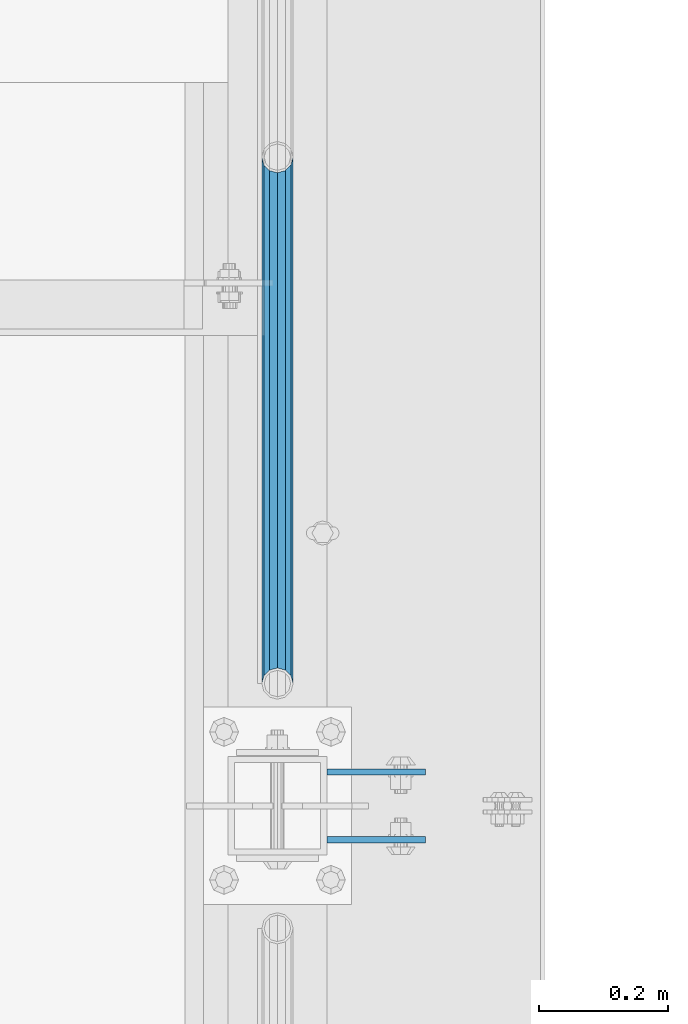
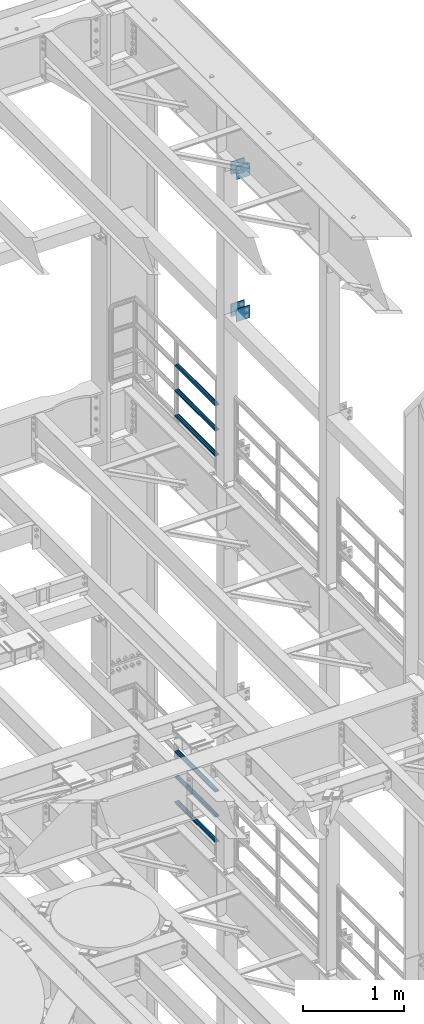
# One storey, part 1349 of 1876: 10 beams, 3 elements without a shape of their own.
"""IFC2X3 building model written with IfcOpenShell, lengths in millimetres."""

from ifc_helpers import new_model, si_unit, frame, origin_with_axes, place, context, subcontext, project, spatial, faceted_brep, material, type_object, element, aggregate, save


model = new_model("IFC2X3")

# Units and contexts
model_context = context("Model", 3, precision=1e-05, world=origin_with_axes())
body_context = subcontext(model_context, "Body", "Model", "MODEL_VIEW")
ifc_project = project(units=[si_unit("LENGTHUNIT", "METRE", prefix="MILLI"), si_unit("AREAUNIT", "SQUARE_METRE"), si_unit("VOLUMEUNIT", "CUBIC_METRE"), si_unit("MASSUNIT", "GRAM", prefix="KILO"), si_unit("TIMEUNIT", "SECOND"), si_unit("PLANEANGLEUNIT", "RADIAN"), si_unit("SOLIDANGLEUNIT", "STERADIAN"), si_unit("THERMODYNAMICTEMPERATUREUNIT", "DEGREE_CELSIUS"), si_unit("LUMINOUSINTENSITYUNIT", "LUMEN")], contexts=[model_context])

# Site, building, storey
site_placement = place(None, origin_with_axes())
site = spatial("IfcSite", under=ifc_project, at=site_placement, CompositionType="ELEMENT")
building_placement = place(site_placement, origin_with_axes())
building = spatial("IfcBuilding", under=site, at=building_placement, Name="Undefined", CompositionType="ELEMENT")
storey_placement = place(building_placement, origin_with_axes())
storey = spatial("IfcBuildingStorey", under=building, at=storey_placement, Name="Undefined", CompositionType="ELEMENT", Elevation=0.0)

# Assembly, beams
assembly_1_placement = place(storey_placement, origin_with_axes())
assembly_1 = element("IfcElementAssembly", 1, at=assembly_1_placement, inside=storey, Name="BEAM", AssemblyPlace="NOTDEFINED", PredefinedType="RIGID_FRAME")
ifc_material_1 = material(Name="STEEL/A36")
beam_type_1 = type_object("IfcBeamType", PredefinedType="NOTDEFINED")
beam_1_placement = place(assembly_1_placement, frame((7696.20000025489, 11736.3875, 21678.9), z_axis=(0.0, 0.0, -1.0), x_axis=(1.0, 0.0, 0.0)))
beam_1 = element("IfcBeam", 2, at=beam_1_placement, type_object=beam_type_1, material=ifc_material_1, Name="PLATE", context=body_context, shape_type="Brep", body=[
    faceted_brep([(0.0, 4.76249999999982, -76.1999999999998), (3.63797880709171e-12, 4.76249999999982, 76.1999969482422), (152.399993896484, 4.76250000000073, 76.1999969482422), (152.4, 4.76249999999982, -76.1999999999998), (3.63797880709171e-12, -4.76249999999982, 76.1999969482422), (152.399993896484, -4.76250000000073, 76.1999969482422), (0.0, -4.76249999999982, -76.1999999999998), (152.4, -4.76249999999982, -76.1999999999998)], [[[0, 1, 2, 3]], [[4, 5, 2, 1]], [[4, 6, 7, 5]], [[6, 0, 3, 7]], [[5, 7, 3, 2]], [[6, 4, 1, 0]]]),
])
beam_2_placement = place(assembly_1_placement, frame((7696.20000025489, 11631.6125, 21678.9), z_axis=(0.0, 0.0, -1.0), x_axis=(1.0, 0.0, 0.0)))
beam_2 = element("IfcBeam", 3, at=beam_2_placement, type_object=beam_type_1, material=ifc_material_1, Name="PLATE", context=body_context, shape_type="Brep", body=[
    faceted_brep([(0.0, 4.76249999999982, -76.1999999999998), (3.63797880709171e-12, 4.76249999999982, 76.1999969482422), (152.399993896484, 4.76250000000073, 76.1999969482422), (152.4, 4.76249999999982, -76.1999999999998), (3.63797880709171e-12, -4.76249999999982, 76.1999969482422), (152.399993896484, -4.76250000000073, 76.1999969482422), (0.0, -4.76249999999982, -76.1999999999998), (152.4, -4.76249999999982, -76.1999999999998)], [[[0, 1, 2, 3]], [[4, 5, 2, 1]], [[4, 6, 7, 5]], [[6, 0, 3, 7]], [[5, 7, 3, 2]], [[6, 4, 1, 0]]]),
])
beam_3_placement = place(assembly_1_placement, frame((7696.20000025489, 11736.3875, 19958.05), z_axis=(0.0, 0.0, -1.0), x_axis=(1.0, 0.0, 0.0)))
beam_3 = element("IfcBeam", 4, at=beam_3_placement, type_object=beam_type_1, material=ifc_material_1, Name="PLATE", context=body_context, shape_type="Brep", body=[
    faceted_brep([(0.0, 4.76249999999982, -76.1999999999998), (3.63797880709171e-12, 4.76249999999982, 76.1999969482422), (152.399993896484, 4.76250000000073, 76.1999969482422), (152.4, 4.76249999999982, -76.1999999999998), (3.63797880709171e-12, -4.76249999999982, 76.1999969482422), (152.399993896484, -4.76250000000073, 76.1999969482422), (0.0, -4.76249999999982, -76.1999999999998), (152.4, -4.76249999999982, -76.1999999999998)], [[[0, 1, 2, 3]], [[4, 5, 2, 1]], [[4, 6, 7, 5]], [[6, 0, 3, 7]], [[5, 7, 3, 2]], [[6, 4, 1, 0]]]),
])
beam_4_placement = place(assembly_1_placement, frame((7696.20000025489, 11631.6125, 19958.05), z_axis=(0.0, 0.0, -1.0), x_axis=(1.0, 0.0, 0.0)))
beam_4 = element("IfcBeam", 5, at=beam_4_placement, type_object=beam_type_1, material=ifc_material_1, Name="PLATE", context=body_context, shape_type="Brep", body=[
    faceted_brep([(0.0, 4.76249999999982, -76.1999999999998), (3.63797880709171e-12, 4.76249999999982, 76.1999969482422), (152.399993896484, 4.76250000000073, 76.1999969482422), (152.4, 4.76249999999982, -76.1999999999998), (3.63797880709171e-12, -4.76249999999982, 76.1999969482422), (152.399993896484, -4.76250000000073, 76.1999969482422), (0.0, -4.76249999999982, -76.1999999999998), (152.4, -4.76249999999982, -76.1999999999998)], [[[0, 1, 2, 3]], [[4, 5, 2, 1]], [[4, 6, 7, 5]], [[6, 0, 3, 7]], [[5, 7, 3, 2]], [[6, 4, 1, 0]]]),
])
aggregate(assembly_1, [beam_1, beam_2, beam_3, beam_4])

assembly_2_placement = place(storey_placement, origin_with_axes())
assembly_2 = element("IfcElementAssembly", 6, at=assembly_2_placement, inside=storey, Name="RAIL", AssemblyPlace="NOTDEFINED", PredefinedType="RIGID_FRAME")
ifc_material_2 = material()
beam_type_2 = type_object("IfcBeamType", Name="PIPE1-1/2SCH40", PredefinedType="NOTDEFINED")
beam_5_placement = place(assembly_2_placement, frame((7619.99999999997, 12686.3094, 18145.125), z_axis=(0.0, 0.0, 1.0), x_axis=(0.0, -1.0, 0.0)))
beam_5 = element("IfcBeam", 7, at=beam_5_placement, type_object=beam_type_2, material=ifc_material_2, Name="RAIL", ObjectType="PIPE1-1/2SCH40", context=body_context, shape_type="Brep", body=[
    faceted_brep([(792.499707006684, -12.0649999999996, 20.8971929933177), (792.499707006684, -12.0650000000314, 15.8661214311469), (792.006278568813, -10.2235000000001, 17.7076214311819), (789.266900000001, -9.09494701772928e-13, 20.4470000000001), (789.266900000001, -9.09494701772928e-13, 24.130000000001), (792.00627856883, 10.2235000000001, 17.7076214311819), (792.499707006684, 12.0649999999678, 15.8661214312124), (792.499707006684, 12.0649999999996, 20.8971929933177), (813.396900000002, 24.1300000000001, 0.0), (801.331900000001, 20.8971929933186, 12.0649999999987), (801.331900000001, 20.8971929933186, -12.0649999999987), (798.142328437896, 17.7076214311801, 10.2235000000001), (800.881707006714, 20.4470000000001, 0.0), (798.142328437896, 17.7076214311801, -10.2235000000001), (792.499707006684, 12.0649999999678, -15.8661214312124), (792.499707006684, 12.0649999999996, -20.8971929933177), (792.00627856883, 10.2235000000001, -17.7076214311819), (789.266900000001, 0.0, -20.4470000000001), (789.266900000001, 0.0, -24.130000000001), (792.499707006684, -12.0650000000314, -15.8661214311469), (792.499707006684, -12.0649999999996, -20.8971929933177), (792.006278568813, -10.2235000000001, -17.7076214311819), (813.396900000002, -24.1300000000319, 0.0), (801.331900000001, -20.8971929933186, -12.0649999999987), (801.331900000001, -20.8971929933186, 12.0649999999987), (798.142328437831, -17.7076214311801, -10.2235000000001), (800.881707006651, -20.4470000000001, 0.0), (798.142328437831, -17.7076214311801, 10.2235000000001), (12.0650000000064, -20.8971929933177, -12.0649999999987), (20.8971929933249, -12.0650000000005, -20.8971929933177), (0.0, 24.1299999999992, 0.0), (12.0650000000064, 20.8971929933177, -12.0649999999987), (12.0650000000064, 20.8971929933177, 12.0649999999987), (20.8971929933249, 12.0650000000005, 20.8971929933177), (24.1300000000064, 0.0, 24.130000000001), (20.8971929933249, 12.0650000000005, -20.8971929933177), (24.1300000000063, 0.0, -24.130000000001), (24.1300000000063, 0.0, -20.4470000000001), (20.8971929933249, -12.0650000000005, -15.8661214311796), (21.3906214311868, -10.2235000000001, -17.7076214311819), (21.3906214311868, 10.2235000000001, -17.7076214311819), (20.8971929933249, 12.0650000000005, -15.8661214311796), (15.2545715621445, 17.7076214311801, -10.2235000000001), (12.5151929933249, 20.4470000000001, 0.0), (15.2545715621445, 17.7076214311801, 10.2235000000001), (20.8971929933249, 12.0650000000005, 15.8661214311796), (21.3906214311868, 10.2235000000001, 17.7076214311819), (24.1300000000064, 0.0, 20.4470000000001), (21.3906214311868, -10.2235000000001, 17.7076214311819), (20.8971929933249, -12.0650000000005, 15.8661214311796), (20.8971929933249, -12.0650000000005, 20.8971929933177), (12.0650000000064, -20.8971929933177, 12.0649999999987), (0.0, -24.1299999999992, 0.0), (15.2545715621445, -17.7076214311801, 10.2235000000001), (12.5151929933249, -20.4470000000001, 0.0), (15.2545715621445, -17.7076214311801, -10.2235000000001)], [[[0, 1, 2, 3, 4]], [[4, 3, 5, 6, 7]], [[8, 9, 10]], [[7, 6, 11, 12, 13, 14, 15, 10, 9]], [[16, 17, 18, 15, 14]], [[19, 20, 18, 17, 21]], [[22, 23, 24]], [[24, 23, 20, 19, 25, 26, 27, 1, 0]], [[28, 29, 20, 23]], [[30, 31, 32]], [[33, 34, 4, 7]], [[32, 33, 7, 9]], [[30, 32, 9, 8]], [[31, 30, 8, 10]], [[35, 31, 10, 15]], [[36, 35, 15, 18]], [[29, 36, 18, 20]], [[37, 36, 29, 38, 39]], [[40, 41, 35, 36, 37]], [[32, 31, 35, 41, 42, 43, 44, 45, 33]], [[33, 45, 46, 47, 34]], [[34, 47, 48, 49, 50]], [[34, 50, 0, 4]], [[50, 51, 24, 0]], [[51, 52, 22, 24]], [[52, 28, 23, 22]], [[51, 28, 52]], [[50, 49, 53, 54, 55, 38, 29, 28, 51]], [[55, 54, 26, 25]], [[21, 39, 38, 55, 25, 19]], [[37, 39, 21, 17]], [[40, 37, 17, 16]], [[42, 41, 40, 16, 14, 13]], [[43, 42, 13, 12]], [[44, 43, 12, 11]], [[5, 46, 45, 44, 11, 6]], [[47, 46, 5, 3]], [[48, 47, 3, 2]], [[53, 49, 48, 2, 1, 27]], [[54, 53, 27, 26]]]),
])
beam_6_placement = place(assembly_2_placement, frame((7619.99999999997, 11872.9125, 18449.925), z_axis=(0.0, 0.0, -1.0), x_axis=(0.0, 1.0, 0.0)))
beam_6 = element("IfcBeam", 8, at=beam_6_placement, type_object=beam_type_2, material=ifc_material_2, Name="RAIL", ObjectType="PIPE1-1/2SCH40", context=body_context, shape_type="Brep", body=[
    faceted_brep([(0.0, 24.1299999999992, 0.0), (12.0650000000064, 20.8971929933177, -12.0649999999987), (12.0650000000064, 20.8971929933177, 12.0649999999987), (12.0650000000064, -20.8971929933177, 12.0649999999987), (12.0650000000064, -20.8971929933177, -12.0649999999987), (0.0, -24.1299999999992, 0.0), (20.8971929933249, -12.0650000000005, 20.8971929933177), (20.8971929933249, -12.0650000000005, 15.8661214311796), (15.2545715621445, -17.7076214311801, 10.2235000000001), (12.5151929933249, -20.4470000000001, 0.0), (15.2545715621445, -17.7076214311801, -10.2235000000001), (20.8971929933249, -12.0650000000005, -15.8661214311796), (20.8971929933249, -12.0650000000005, -20.8971929933177), (24.1300000000063, 0.0, -20.4470000000001), (24.1300000000063, 0.0, -24.130000000001), (21.3906214311868, -10.2235000000001, -17.7076214311819), (21.3906214311868, 10.2235000000001, -17.7076214311819), (20.8971929933249, 12.0650000000005, -15.8661214311796), (20.8971929933249, 12.0650000000005, -20.8971929933177), (15.2545715621445, 17.7076214311801, -10.2235000000001), (12.5151929933249, 20.4470000000001, 0.0), (15.2545715621445, 17.7076214311801, 10.2235000000001), (20.8971929933249, 12.0650000000005, 15.8661214311796), (20.8971929933249, 12.0650000000005, 20.8971929933177), (21.3906214311868, 10.2235000000001, 17.7076214311819), (24.1300000000064, 0.0, 20.4470000000001), (24.1300000000064, 0.0, 24.130000000001), (21.3906214311868, -10.2235000000001, 17.7076214311819), (813.396900000002, 24.1300000000001, 0.0), (801.331900000001, 20.8971929933186, -12.0649999999987), (792.499707006684, 12.0649999999996, -20.8971929933177), (813.396900000002, -24.1300000000319, 0.0), (801.331900000001, -20.8971929933186, -12.0649999999987), (801.331900000001, -20.8971929933186, 12.0649999999987), (792.499707006684, -12.0649999999996, 20.8971929933177), (792.499707006684, -12.0649999999996, -20.8971929933177), (789.266900000001, 0.0, -24.130000000001), (792.00627856883, 10.2235000000001, -17.7076214311819), (789.266900000001, 0.0, -20.4470000000001), (792.499707006684, 12.0649999999678, -15.8661214312124), (792.499707006684, -12.0650000000314, -15.8661214311469), (792.006278568813, -10.2235000000001, -17.7076214311819), (798.142328437831, -17.7076214311801, -10.2235000000001), (800.881707006651, -20.4470000000001, 0.0), (798.142328437831, -17.7076214311801, 10.2235000000001), (792.499707006684, -12.0650000000314, 15.8661214311469), (792.006278568813, -10.2235000000001, 17.7076214311819), (789.266900000001, -9.09494701772928e-13, 20.4470000000001), (789.266900000001, -9.09494701772928e-13, 24.130000000001), (792.499707006684, 12.0649999999996, 20.8971929933177), (801.331900000001, 20.8971929933186, 12.0649999999987), (792.499707006684, 12.0649999999678, 15.8661214312124), (798.142328437896, 17.7076214311801, 10.2235000000001), (800.881707006714, 20.4470000000001, 0.0), (798.142328437896, 17.7076214311801, -10.2235000000001), (792.00627856883, 10.2235000000001, 17.7076214311819)], [[[0, 1, 2]], [[3, 4, 5]], [[6, 7, 8, 9, 10, 11, 12, 4, 3]], [[13, 14, 12, 11, 15]], [[16, 17, 18, 14, 13]], [[2, 1, 18, 17, 19, 20, 21, 22, 23]], [[23, 22, 24, 25, 26]], [[26, 25, 27, 7, 6]], [[1, 0, 28, 29]], [[18, 1, 29, 30]], [[31, 32, 33]], [[6, 3, 33, 34]], [[3, 5, 31, 33]], [[5, 4, 32, 31]], [[4, 12, 35, 32]], [[12, 14, 36, 35]], [[14, 18, 30, 36]], [[37, 38, 36, 30, 39]], [[40, 35, 36, 38, 41]], [[33, 32, 35, 40, 42, 43, 44, 45, 34]], [[34, 45, 46, 47, 48]], [[26, 6, 34, 48]], [[2, 23, 49, 50]], [[23, 26, 48, 49]], [[0, 2, 50, 28]], [[28, 50, 29]], [[49, 51, 52, 53, 54, 39, 30, 29, 50]], [[48, 47, 55, 51, 49]], [[25, 24, 55, 47]], [[55, 24, 22, 21, 52, 51]], [[21, 20, 53, 52]], [[20, 19, 54, 53]], [[19, 17, 16, 37, 39, 54]], [[16, 13, 38, 37]], [[13, 15, 41, 38]], [[41, 15, 11, 10, 42, 40]], [[10, 9, 43, 42]], [[9, 8, 44, 43]], [[8, 7, 27, 46, 45, 44]], [[27, 25, 47, 46]]]),
])
beam_7_placement = place(assembly_2_placement, frame((7619.99999999997, 11872.9125, 18754.725), z_axis=(0.0, 0.0, -1.0), x_axis=(0.0, 1.0, 0.0)))
beam_7 = element("IfcBeam", 9, at=beam_7_placement, type_object=beam_type_2, material=ifc_material_2, Name="RAIL", ObjectType="PIPE1-1/2SCH40", context=body_context, shape_type="Brep", body=[
    faceted_brep([(0.0, 24.1299999999992, 0.0), (12.0650000000064, 20.8971929933177, -12.0649999999987), (12.0650000000064, 20.8971929933177, 12.0649999999987), (12.0650000000064, -20.8971929933177, 12.0649999999987), (12.0650000000064, -20.8971929933177, -12.0649999999987), (0.0, -24.1299999999992, 0.0), (20.8971929933249, -12.0650000000005, 20.8971929933177), (20.8971929933249, -12.0650000000005, 15.8661214311796), (15.2545715621445, -17.7076214311801, 10.2235000000001), (12.5151929933249, -20.4470000000001, 0.0), (15.2545715621445, -17.7076214311801, -10.2235000000001), (20.8971929933249, -12.0650000000005, -15.8661214311796), (20.8971929933249, -12.0650000000005, -20.8971929933177), (24.1300000000063, 0.0, -20.4470000000001), (24.1300000000063, 0.0, -24.130000000001), (21.3906214311868, -10.2235000000001, -17.7076214311819), (21.3906214311868, 10.2235000000001, -17.7076214311819), (20.8971929933249, 12.0650000000005, -15.8661214311796), (20.8971929933249, 12.0650000000005, -20.8971929933177), (15.2545715621445, 17.7076214311801, -10.2235000000001), (12.5151929933249, 20.4470000000001, 0.0), (15.2545715621445, 17.7076214311801, 10.2235000000001), (20.8971929933249, 12.0650000000005, 15.8661214311796), (20.8971929933249, 12.0650000000005, 20.8971929933177), (21.3906214311868, 10.2235000000001, 17.7076214311819), (24.1300000000064, 0.0, 20.4470000000001), (24.1300000000064, 0.0, 24.130000000001), (21.3906214311868, -10.2235000000001, 17.7076214311819), (813.396900000002, 24.1300000000001, 0.0), (801.331900000001, 20.8971929933186, -12.0649999999987), (792.499707006684, 12.0649999999996, -20.8971929933177), (813.396900000002, -24.1300000000319, 0.0), (801.331900000001, -20.8971929933186, -12.0649999999987), (801.331900000001, -20.8971929933186, 12.0649999999987), (792.499707006684, -12.0649999999996, 20.8971929933177), (792.499707006684, -12.0649999999996, -20.8971929933177), (789.266900000001, 0.0, -24.130000000001), (792.00627856883, 10.2235000000001, -17.7076214311819), (789.266900000001, 0.0, -20.4470000000001), (792.499707006684, 12.0649999999678, -15.8661214312124), (792.499707006684, -12.0650000000314, -15.8661214311469), (792.006278568813, -10.2235000000001, -17.7076214311819), (798.142328437831, -17.7076214311801, -10.2235000000001), (800.881707006651, -20.4470000000001, 0.0), (798.142328437831, -17.7076214311801, 10.2235000000001), (792.499707006684, -12.0650000000314, 15.8661214311469), (792.006278568813, -10.2235000000001, 17.7076214311819), (789.266900000001, -9.09494701772928e-13, 20.4470000000001), (789.266900000001, -9.09494701772928e-13, 24.130000000001), (792.499707006684, 12.0649999999996, 20.8971929933177), (801.331900000001, 20.8971929933186, 12.0649999999987), (792.499707006684, 12.0649999999678, 15.8661214312124), (798.142328437896, 17.7076214311801, 10.2235000000001), (800.881707006714, 20.4470000000001, 0.0), (798.142328437896, 17.7076214311801, -10.2235000000001), (792.00627856883, 10.2235000000001, 17.7076214311819)], [[[0, 1, 2]], [[3, 4, 5]], [[6, 7, 8, 9, 10, 11, 12, 4, 3]], [[13, 14, 12, 11, 15]], [[16, 17, 18, 14, 13]], [[2, 1, 18, 17, 19, 20, 21, 22, 23]], [[23, 22, 24, 25, 26]], [[26, 25, 27, 7, 6]], [[1, 0, 28, 29]], [[18, 1, 29, 30]], [[31, 32, 33]], [[6, 3, 33, 34]], [[3, 5, 31, 33]], [[5, 4, 32, 31]], [[4, 12, 35, 32]], [[12, 14, 36, 35]], [[14, 18, 30, 36]], [[37, 38, 36, 30, 39]], [[40, 35, 36, 38, 41]], [[33, 32, 35, 40, 42, 43, 44, 45, 34]], [[34, 45, 46, 47, 48]], [[26, 6, 34, 48]], [[2, 23, 49, 50]], [[23, 26, 48, 49]], [[0, 2, 50, 28]], [[28, 50, 29]], [[49, 51, 52, 53, 54, 39, 30, 29, 50]], [[48, 47, 55, 51, 49]], [[25, 24, 55, 47]], [[55, 24, 22, 21, 52, 51]], [[21, 20, 53, 52]], [[20, 19, 54, 53]], [[19, 17, 16, 37, 39, 54]], [[16, 13, 38, 37]], [[13, 15, 41, 38]], [[41, 15, 11, 10, 42, 40]], [[10, 9, 43, 42]], [[9, 8, 44, 43]], [[8, 7, 27, 46, 45, 44]], [[27, 25, 47, 46]]]),
])
aggregate(assembly_2, [beam_5, beam_6, beam_7])

assembly_3_placement = place(storey_placement, origin_with_axes())
assembly_3 = element("IfcElementAssembly", 10, at=assembly_3_placement, inside=storey, Name="RAIL", AssemblyPlace="NOTDEFINED", PredefinedType="RIGID_FRAME")
beam_8_placement = place(assembly_3_placement, frame((7619.99999999997, 12686.3094, 13471.525), z_axis=(0.0, 0.0, 1.0), x_axis=(0.0, -1.0, 0.0)))
beam_8 = element("IfcBeam", 11, at=beam_8_placement, type_object=beam_type_2, material=ifc_material_2, Name="RAIL", ObjectType="PIPE1-1/2SCH40", context=body_context, shape_type="Brep", body=[
    faceted_brep([(792.499707006684, -12.0649999999996, 20.8971929933177), (792.499707006684, -12.0650000000314, 15.8661214311469), (792.006278568813, -10.2235000000001, 17.7076214311819), (789.266900000001, -9.09494701772928e-13, 20.4470000000001), (789.266900000001, -9.09494701772928e-13, 24.130000000001), (792.00627856883, 10.2235000000001, 17.7076214311819), (792.499707006684, 12.0649999999678, 15.8661214312124), (792.499707006684, 12.0649999999996, 20.8971929933177), (813.396900000002, 24.1300000000001, 0.0), (801.331900000001, 20.8971929933186, 12.0649999999987), (801.331900000001, 20.8971929933186, -12.0649999999987), (798.142328437896, 17.7076214311801, 10.2235000000001), (800.881707006714, 20.4470000000001, 0.0), (798.142328437896, 17.7076214311801, -10.2235000000001), (792.499707006684, 12.0649999999678, -15.8661214312124), (792.499707006684, 12.0649999999996, -20.8971929933177), (792.00627856883, 10.2235000000001, -17.7076214311819), (789.266900000001, 0.0, -20.4470000000001), (789.266900000001, 0.0, -24.130000000001), (792.499707006684, -12.0650000000314, -15.8661214311469), (792.499707006684, -12.0649999999996, -20.8971929933177), (792.006278568813, -10.2235000000001, -17.7076214311819), (813.396900000002, -24.1300000000319, 0.0), (801.331900000001, -20.8971929933186, -12.0649999999987), (801.331900000001, -20.8971929933186, 12.0649999999987), (798.142328437831, -17.7076214311801, -10.2235000000001), (800.881707006651, -20.4470000000001, 0.0), (798.142328437831, -17.7076214311801, 10.2235000000001), (12.0650000000064, -20.8971929933177, -12.0649999999987), (20.8971929933249, -12.0650000000005, -20.8971929933177), (0.0, 24.1299999999992, 0.0), (12.0650000000064, 20.8971929933177, -12.0649999999987), (12.0650000000064, 20.8971929933177, 12.0649999999987), (20.8971929933249, 12.0650000000005, 20.8971929933177), (24.1300000000064, 0.0, 24.130000000001), (20.8971929933249, 12.0650000000005, -20.8971929933177), (24.1300000000063, 0.0, -24.130000000001), (24.1300000000063, 0.0, -20.4470000000001), (20.8971929933249, -12.0650000000005, -15.8661214311796), (21.3906214311868, -10.2235000000001, -17.7076214311819), (21.3906214311868, 10.2235000000001, -17.7076214311819), (20.8971929933249, 12.0650000000005, -15.8661214311796), (15.2545715621445, 17.7076214311801, -10.2235000000001), (12.5151929933249, 20.4470000000001, 0.0), (15.2545715621445, 17.7076214311801, 10.2235000000001), (20.8971929933249, 12.0650000000005, 15.8661214311796), (21.3906214311868, 10.2235000000001, 17.7076214311819), (24.1300000000064, 0.0, 20.4470000000001), (21.3906214311868, -10.2235000000001, 17.7076214311819), (20.8971929933249, -12.0650000000005, 15.8661214311796), (20.8971929933249, -12.0650000000005, 20.8971929933177), (12.0650000000064, -20.8971929933177, 12.0649999999987), (0.0, -24.1299999999992, 0.0), (15.2545715621445, -17.7076214311801, 10.2235000000001), (12.5151929933249, -20.4470000000001, 0.0), (15.2545715621445, -17.7076214311801, -10.2235000000001)], [[[0, 1, 2, 3, 4]], [[4, 3, 5, 6, 7]], [[8, 9, 10]], [[7, 6, 11, 12, 13, 14, 15, 10, 9]], [[16, 17, 18, 15, 14]], [[19, 20, 18, 17, 21]], [[22, 23, 24]], [[24, 23, 20, 19, 25, 26, 27, 1, 0]], [[28, 29, 20, 23]], [[30, 31, 32]], [[33, 34, 4, 7]], [[32, 33, 7, 9]], [[30, 32, 9, 8]], [[31, 30, 8, 10]], [[35, 31, 10, 15]], [[36, 35, 15, 18]], [[29, 36, 18, 20]], [[37, 36, 29, 38, 39]], [[40, 41, 35, 36, 37]], [[32, 31, 35, 41, 42, 43, 44, 45, 33]], [[33, 45, 46, 47, 34]], [[34, 47, 48, 49, 50]], [[34, 50, 0, 4]], [[50, 51, 24, 0]], [[51, 52, 22, 24]], [[52, 28, 23, 22]], [[51, 28, 52]], [[50, 49, 53, 54, 55, 38, 29, 28, 51]], [[55, 54, 26, 25]], [[21, 39, 38, 55, 25, 19]], [[37, 39, 21, 17]], [[40, 37, 17, 16]], [[42, 41, 40, 16, 14, 13]], [[43, 42, 13, 12]], [[44, 43, 12, 11]], [[5, 46, 45, 44, 11, 6]], [[47, 46, 5, 3]], [[48, 47, 3, 2]], [[53, 49, 48, 2, 1, 27]], [[54, 53, 27, 26]]]),
])
beam_9_placement = place(assembly_3_placement, frame((7619.99999999997, 11872.9125, 13776.325), z_axis=(0.0, 0.0, -1.0), x_axis=(0.0, 1.0, 0.0)))
beam_9 = element("IfcBeam", 12, at=beam_9_placement, type_object=beam_type_2, material=ifc_material_2, Name="RAIL", ObjectType="PIPE1-1/2SCH40", context=body_context, shape_type="Brep", body=[
    faceted_brep([(0.0, 24.1299999999992, 0.0), (12.0650000000064, 20.8971929933177, -12.0649999999987), (12.0650000000064, 20.8971929933177, 12.0649999999987), (12.0650000000064, -20.8971929933177, 12.0649999999987), (12.0650000000064, -20.8971929933177, -12.0649999999987), (0.0, -24.1299999999992, 0.0), (20.8971929933249, -12.0650000000005, 20.8971929933177), (20.8971929933249, -12.0650000000005, 15.8661214311796), (15.2545715621445, -17.7076214311801, 10.2235000000001), (12.5151929933249, -20.4470000000001, 0.0), (15.2545715621445, -17.7076214311801, -10.2235000000001), (20.8971929933249, -12.0650000000005, -15.8661214311796), (20.8971929933249, -12.0650000000005, -20.8971929933177), (24.1300000000063, 0.0, -20.4470000000001), (24.1300000000063, 0.0, -24.130000000001), (21.3906214311868, -10.2235000000001, -17.7076214311819), (21.3906214311868, 10.2235000000001, -17.7076214311819), (20.8971929933249, 12.0650000000005, -15.8661214311796), (20.8971929933249, 12.0650000000005, -20.8971929933177), (15.2545715621445, 17.7076214311801, -10.2235000000001), (12.5151929933249, 20.4470000000001, 0.0), (15.2545715621445, 17.7076214311801, 10.2235000000001), (20.8971929933249, 12.0650000000005, 15.8661214311796), (20.8971929933249, 12.0650000000005, 20.8971929933177), (21.3906214311868, 10.2235000000001, 17.7076214311819), (24.1300000000064, 0.0, 20.4470000000001), (24.1300000000064, 0.0, 24.130000000001), (21.3906214311868, -10.2235000000001, 17.7076214311819), (813.396900000002, 24.1300000000001, 0.0), (801.331900000001, 20.8971929933186, -12.0649999999987), (792.499707006684, 12.0649999999996, -20.8971929933177), (813.396900000002, -24.1300000000319, 0.0), (801.331900000001, -20.8971929933186, -12.0649999999987), (801.331900000001, -20.8971929933186, 12.0649999999987), (792.499707006684, -12.0649999999996, 20.8971929933177), (792.499707006684, -12.0649999999996, -20.8971929933177), (789.266900000001, 0.0, -24.130000000001), (792.00627856883, 10.2235000000001, -17.7076214311819), (789.266900000001, 0.0, -20.4470000000001), (792.499707006684, 12.0649999999678, -15.8661214312124), (792.499707006684, -12.0650000000314, -15.8661214311469), (792.006278568813, -10.2235000000001, -17.7076214311819), (798.142328437831, -17.7076214311801, -10.2235000000001), (800.881707006651, -20.4470000000001, 0.0), (798.142328437831, -17.7076214311801, 10.2235000000001), (792.499707006684, -12.0650000000314, 15.8661214311469), (792.006278568813, -10.2235000000001, 17.7076214311819), (789.266900000001, -9.09494701772928e-13, 20.4470000000001), (789.266900000001, -9.09494701772928e-13, 24.130000000001), (792.499707006684, 12.0649999999996, 20.8971929933177), (801.331900000001, 20.8971929933186, 12.0649999999987), (792.499707006684, 12.0649999999678, 15.8661214312124), (798.142328437896, 17.7076214311801, 10.2235000000001), (800.881707006714, 20.4470000000001, 0.0), (798.142328437896, 17.7076214311801, -10.2235000000001), (792.00627856883, 10.2235000000001, 17.7076214311819)], [[[0, 1, 2]], [[3, 4, 5]], [[6, 7, 8, 9, 10, 11, 12, 4, 3]], [[13, 14, 12, 11, 15]], [[16, 17, 18, 14, 13]], [[2, 1, 18, 17, 19, 20, 21, 22, 23]], [[23, 22, 24, 25, 26]], [[26, 25, 27, 7, 6]], [[1, 0, 28, 29]], [[18, 1, 29, 30]], [[31, 32, 33]], [[6, 3, 33, 34]], [[3, 5, 31, 33]], [[5, 4, 32, 31]], [[4, 12, 35, 32]], [[12, 14, 36, 35]], [[14, 18, 30, 36]], [[37, 38, 36, 30, 39]], [[40, 35, 36, 38, 41]], [[33, 32, 35, 40, 42, 43, 44, 45, 34]], [[34, 45, 46, 47, 48]], [[26, 6, 34, 48]], [[2, 23, 49, 50]], [[23, 26, 48, 49]], [[0, 2, 50, 28]], [[28, 50, 29]], [[49, 51, 52, 53, 54, 39, 30, 29, 50]], [[48, 47, 55, 51, 49]], [[25, 24, 55, 47]], [[55, 24, 22, 21, 52, 51]], [[21, 20, 53, 52]], [[20, 19, 54, 53]], [[19, 17, 16, 37, 39, 54]], [[16, 13, 38, 37]], [[13, 15, 41, 38]], [[41, 15, 11, 10, 42, 40]], [[10, 9, 43, 42]], [[9, 8, 44, 43]], [[8, 7, 27, 46, 45, 44]], [[27, 25, 47, 46]]]),
])
beam_10_placement = place(assembly_3_placement, frame((7619.99999999997, 11872.9125, 14081.125), z_axis=(0.0, 0.0, -1.0), x_axis=(0.0, 1.0, 0.0)))
beam_10 = element("IfcBeam", 13, at=beam_10_placement, type_object=beam_type_2, material=ifc_material_2, Name="RAIL", ObjectType="PIPE1-1/2SCH40", context=body_context, shape_type="Brep", body=[
    faceted_brep([(0.0, 24.1299999999992, 0.0), (12.0650000000064, 20.8971929933177, -12.0649999999987), (12.0650000000064, 20.8971929933177, 12.0649999999987), (12.0650000000064, -20.8971929933177, 12.0649999999987), (12.0650000000064, -20.8971929933177, -12.0649999999987), (0.0, -24.1299999999992, 0.0), (20.8971929933249, -12.0650000000005, 20.8971929933177), (20.8971929933249, -12.0650000000005, 15.8661214311796), (15.2545715621445, -17.7076214311801, 10.2235000000001), (12.5151929933249, -20.4470000000001, 0.0), (15.2545715621445, -17.7076214311801, -10.2235000000001), (20.8971929933249, -12.0650000000005, -15.8661214311796), (20.8971929933249, -12.0650000000005, -20.8971929933177), (24.1300000000063, 0.0, -20.4470000000001), (24.1300000000063, 0.0, -24.130000000001), (21.3906214311868, -10.2235000000001, -17.7076214311819), (21.3906214311868, 10.2235000000001, -17.7076214311819), (20.8971929933249, 12.0650000000005, -15.8661214311796), (20.8971929933249, 12.0650000000005, -20.8971929933177), (15.2545715621445, 17.7076214311801, -10.2235000000001), (12.5151929933249, 20.4470000000001, 0.0), (15.2545715621445, 17.7076214311801, 10.2235000000001), (20.8971929933249, 12.0650000000005, 15.8661214311796), (20.8971929933249, 12.0650000000005, 20.8971929933177), (21.3906214311868, 10.2235000000001, 17.7076214311819), (24.1300000000064, 0.0, 20.4470000000001), (24.1300000000064, 0.0, 24.130000000001), (21.3906214311868, -10.2235000000001, 17.7076214311819), (813.396900000002, 24.1300000000001, 0.0), (801.331900000001, 20.8971929933186, -12.0649999999987), (792.499707006684, 12.0649999999996, -20.8971929933177), (813.396900000002, -24.1300000000319, 0.0), (801.331900000001, -20.8971929933186, -12.0649999999987), (801.331900000001, -20.8971929933186, 12.0649999999987), (792.499707006684, -12.0649999999996, 20.8971929933177), (792.499707006684, -12.0649999999996, -20.8971929933177), (789.266900000001, 0.0, -24.130000000001), (792.00627856883, 10.2235000000001, -17.7076214311819), (789.266900000001, 0.0, -20.4470000000001), (792.499707006684, 12.0649999999678, -15.8661214312124), (792.499707006684, -12.0650000000314, -15.8661214311469), (792.006278568813, -10.2235000000001, -17.7076214311819), (798.142328437831, -17.7076214311801, -10.2235000000001), (800.881707006651, -20.4470000000001, 0.0), (798.142328437831, -17.7076214311801, 10.2235000000001), (792.499707006684, -12.0650000000314, 15.8661214311469), (792.006278568813, -10.2235000000001, 17.7076214311819), (789.266900000001, -9.09494701772928e-13, 20.4470000000001), (789.266900000001, -9.09494701772928e-13, 24.130000000001), (792.499707006684, 12.0649999999996, 20.8971929933177), (801.331900000001, 20.8971929933186, 12.0649999999987), (792.499707006684, 12.0649999999678, 15.8661214312124), (798.142328437896, 17.7076214311801, 10.2235000000001), (800.881707006714, 20.4470000000001, 0.0), (798.142328437896, 17.7076214311801, -10.2235000000001), (792.00627856883, 10.2235000000001, 17.7076214311819)], [[[0, 1, 2]], [[3, 4, 5]], [[6, 7, 8, 9, 10, 11, 12, 4, 3]], [[13, 14, 12, 11, 15]], [[16, 17, 18, 14, 13]], [[2, 1, 18, 17, 19, 20, 21, 22, 23]], [[23, 22, 24, 25, 26]], [[26, 25, 27, 7, 6]], [[1, 0, 28, 29]], [[18, 1, 29, 30]], [[31, 32, 33]], [[6, 3, 33, 34]], [[3, 5, 31, 33]], [[5, 4, 32, 31]], [[4, 12, 35, 32]], [[12, 14, 36, 35]], [[14, 18, 30, 36]], [[37, 38, 36, 30, 39]], [[40, 35, 36, 38, 41]], [[33, 32, 35, 40, 42, 43, 44, 45, 34]], [[34, 45, 46, 47, 48]], [[26, 6, 34, 48]], [[2, 23, 49, 50]], [[23, 26, 48, 49]], [[0, 2, 50, 28]], [[28, 50, 29]], [[49, 51, 52, 53, 54, 39, 30, 29, 50]], [[48, 47, 55, 51, 49]], [[25, 24, 55, 47]], [[55, 24, 22, 21, 52, 51]], [[21, 20, 53, 52]], [[20, 19, 54, 53]], [[19, 17, 16, 37, 39, 54]], [[16, 13, 38, 37]], [[13, 15, 41, 38]], [[41, 15, 11, 10, 42, 40]], [[10, 9, 43, 42]], [[9, 8, 44, 43]], [[8, 7, 27, 46, 45, 44]], [[27, 25, 47, 46]]]),
])
aggregate(assembly_3, [beam_8, beam_9, beam_10])

save(model, "model.ifc")
